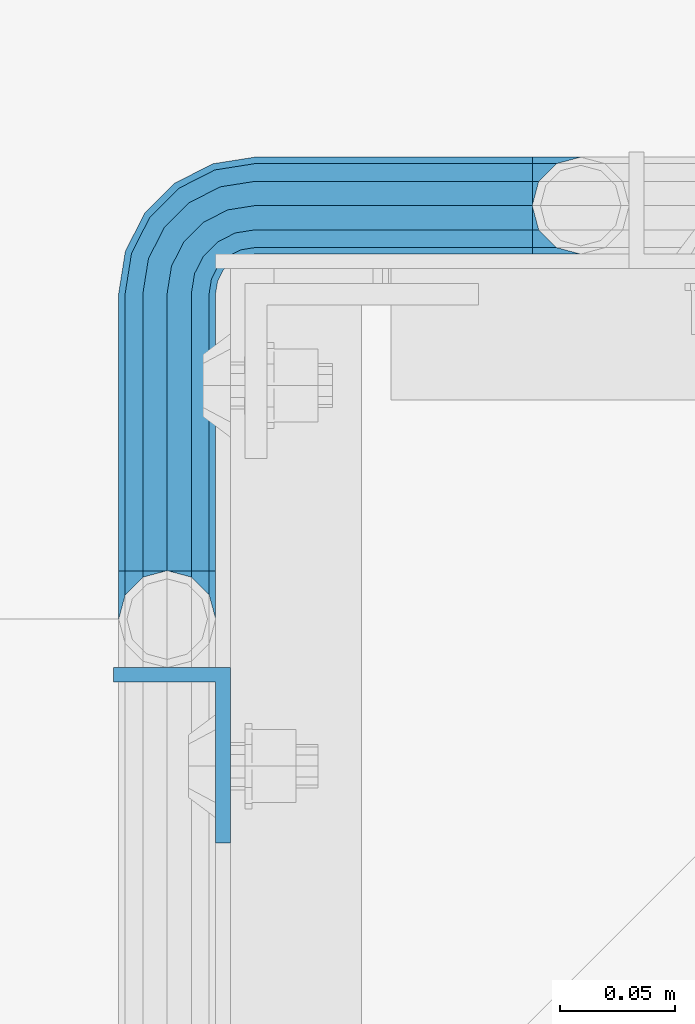
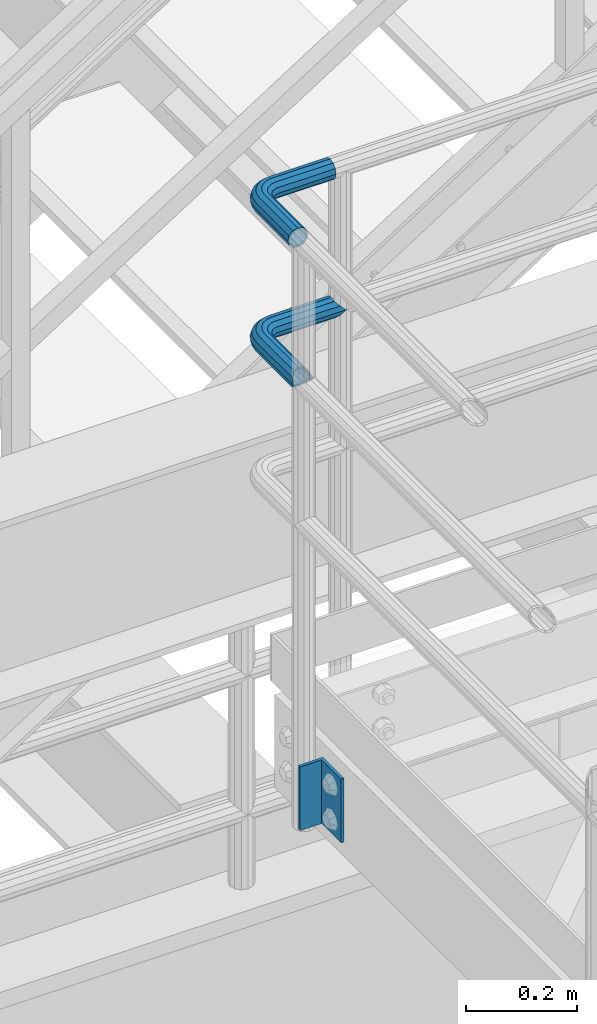
# One storey, part 1130 of 1876: 3 beams, 2 elements without a shape of their own.
"""IFC2X3 building model written with IfcOpenShell, lengths in millimetres."""

from ifc_helpers import new_model, si_unit, frame, origin_with_axes, place, context, subcontext, project, spatial, faceted_brep, material, type_object, element, aggregate, save


model = new_model("IFC2X3")

# Units and contexts
model_context = context("Model", 3, precision=1e-05, world=origin_with_axes())
body_context = subcontext(model_context, "Body", "Model", "MODEL_VIEW")
ifc_project = project(units=[si_unit("LENGTHUNIT", "METRE", prefix="MILLI"), si_unit("AREAUNIT", "SQUARE_METRE"), si_unit("VOLUMEUNIT", "CUBIC_METRE"), si_unit("MASSUNIT", "GRAM", prefix="KILO"), si_unit("TIMEUNIT", "SECOND"), si_unit("PLANEANGLEUNIT", "RADIAN"), si_unit("SOLIDANGLEUNIT", "STERADIAN"), si_unit("THERMODYNAMICTEMPERATUREUNIT", "DEGREE_CELSIUS"), si_unit("LUMINOUSINTENSITYUNIT", "LUMEN")], contexts=[model_context])

# Site, building, storey
site_placement = place(None, origin_with_axes())
site = spatial("IfcSite", under=ifc_project, at=site_placement, CompositionType="ELEMENT")
building_placement = place(site_placement, origin_with_axes())
building = spatial("IfcBuilding", under=site, at=building_placement, Name="Undefined", CompositionType="ELEMENT")
storey_placement = place(building_placement, origin_with_axes())
storey = spatial("IfcBuildingStorey", under=building, at=storey_placement, Name="Undefined", CompositionType="ELEMENT", Elevation=0.0)

# Assembly, beams
assembly_1_placement = place(storey_placement, origin_with_axes())
assembly_1 = element("IfcElementAssembly", 1, at=assembly_1_placement, inside=storey, Name="HANDRAIL", AssemblyPlace="NOTDEFINED", PredefinedType="RIGID_FRAME")
ifc_material_1 = material()
beam_type_1 = type_object("IfcBeamType", Name="PIPE1-1/4STD", PredefinedType="NOTDEFINED")
beam_1_placement = place(assembly_1_placement, frame((3517.90474593762, -7694.13240429563, 8785.225), z_axis=(0.0, 0.0, -1.0), x_axis=(-1.0, 0.0, 0.0)))
beam_1 = element("IfcBeam", 2, at=beam_1_placement, type_object=beam_type_1, material=ifc_material_1, Name="HANDRAIL", ObjectType="PIPE1-1/4STD", context=body_context, shape_type="Brep", body=[
    faceted_brep([(9.09494701772928e-13, 21.0820000000003, 0.0), (10.5409999957128, 18.2575475579433, -10.5409999999993), (10.5409999999983, 18.2575475625836, 10.5410000000011), (10.5409999999983, -18.2575475625836, 10.5410000000011), (10.5409999957128, -18.2575475672238, -10.5409999999993), (9.09494701772928e-13, -21.0820000000003, 0.0), (18.2575475625817, -10.5410000000011, 18.2575475625836), (18.2575475625817, -10.5409999999974, 13.3999612267289), (13.6205863358537, -15.1779612267255, 8.76300000000083), (11.2725475625793, -17.5259999999998, 0.0), (13.6205863358537, -15.1779612267255, -8.76299999999901), (18.2575475625817, -10.5409999999974, -13.3999612267271), (18.2575475625817, -10.5410000000011, -18.2575475625836), (21.0819999999985, 0.0, -17.5259999999998), (21.0819999999985, 0.0, -21.0819999999985), (18.7339612267233, -8.76300000000083, -15.1779612267255), (18.7339612267251, 8.76299999999901, -15.1779612267255), (18.2575475625817, 10.5410000000011, -13.3999612267235), (18.2575475625817, 10.5409999999993, -18.2575475625836), (13.6205863358573, 15.1779612267255, -8.76299999999901), (11.2725475625839, 17.5259999999998, 0.0), (13.6205863358573, 15.1779612267255, 8.76300000000083), (18.2575475625817, 10.5410000000011, 13.3999612267253), (18.2575475625817, 10.5409999999993, 18.2575475625836), (18.7339612267251, 8.76299999999901, 15.1779612267273), (21.0819999999985, 1.81898940354586e-12, 17.5259999999998), (21.0819999999985, 1.81898940354586e-12, 21.0820000000003), (18.7339612267233, -8.76300000000083, 15.1779612267273), (141.7320022583, -8.7629999999981, 15.1779612267255), (141.7320022583, 1.81898940354586e-12, 17.525999999998), (153.505549272468, -1.86474665447258, 17.525999999998), (150.797633350759, -10.1988549067664, 15.1779612267237), (141.7320022583, -15.1779612267246, 8.76299999999901), (148.815301313444, -16.2998455832249, 8.76299999999901), (141.732002258301, -17.5259999999989, -1.81898940354586e-12), (148.08971742905, -18.5329631590612, -1.81898940354586e-12), (141.7320022583, -15.1779612267246, -8.76300000000083), (148.815301313443, -16.2998455832249, -8.76300000000083), (141.7320022583, -8.76299999999901, -15.1779612267273), (150.797633350759, -10.1988549067664, -15.1779612267273), (141.7320022583, 1.81898940354586e-12, -17.5260000000017), (153.505549272467, -1.86474665447258, -17.5260000000017), (141.7320022583, 8.76300000000174, -15.1779612267273), (156.213465194176, 6.46936159782217, -15.1779612267273), (141.7320022583, 15.1779612267273, -8.76300000000083), (158.195797231491, 12.5703522742806, -8.76300000000083), (141.7320022583, 17.5260000000017, -1.81898940354586e-12), (158.921381115884, 14.803469850116, -1.81898940354586e-12), (141.7320022583, 15.1779612267273, 8.76299999999901), (158.195797231491, 12.5703522742806, 8.76299999999901), (141.7320022583, 8.76300000000174, 15.1779612267255), (156.213465194176, 6.46936159782217, 15.1779612267237), (179.832000732422, -38.0999984741202, -17.5260000000017), (171.069000732422, -38.0999984741202, -15.1779612267273), (171.069000732422, -161.097989750122, -15.1779612267255), (179.832000732422, -158.7499511731, -17.5259999999998), (188.595000732423, -38.0999984741202, -15.1779612267273), (188.595000732422, -161.097990142627, -15.1779612267255), (169.291000732422, -38.0999984741202, -18.2575475625854), (179.832000732422, -38.0999984741202, -21.0820000000003), (179.832000732422, -158.7499511731, -21.0820000000003), (169.291000732422, -161.574403610517, -18.2575475625836), (161.574453169838, -38.0999984741193, -10.5410000000011), (161.574453169838, -169.2909511731, -10.5409999999993), (158.750000732422, -38.0999984741193, -1.81898940354586e-12), (158.750000732422, -179.831954956055, 0.0), (161.574453169838, -169.2909511731, 10.5409999999993), (161.574453169839, -38.0999984741193, 10.5409999999993), (169.291000732423, -38.0999984741193, 18.2575475625817), (169.291000732422, -161.574403610517, 18.2575475625836), (179.832000732423, -38.0999984741193, 21.0819999999985), (179.832000732422, -158.7499511731, 21.0820000000003), (141.7320022583, 10.5410000000011, 18.2575475625817), (141.7320022583, 18.2575475625854, 10.5409999999993), (141.7320022583, 21.0820000000012, -1.81898940354586e-12), (141.7320022583, 18.2575475625854, -10.5410000000011), (141.7320022583, 10.5410000000011, -18.2575475625854), (141.7320022583, 1.81898940354586e-12, -21.0820000000022), (141.7320022583, -10.5409999999983, -18.2575475625854), (141.7320022583, -18.2575475625817, -10.5410000000011), (141.732002258301, -21.0819999999985, -1.81898940354586e-12), (141.7320022583, -18.2575475625817, 10.5409999999993), (141.7320022583, -10.5409999999983, 18.2575475625817), (141.7320022583, 1.81898940354586e-12, 21.0819999999985), (153.505549272468, -1.86474665447258, 21.0819999999985), (156.762897410175, 8.16034008379484, 18.2575475625817), (159.147441744916, 15.4992129264911, 10.5409999999993), (160.020245547882, 18.1854268220623, -1.81898940354586e-12), (159.147441744916, 15.4992129264911, -10.5410000000011), (156.762897410174, 8.16034008379484, -18.2575475625854), (153.505549272467, -1.86474665447258, -21.0820000000022), (150.24820113476, -11.8898333927391, -18.2575475625854), (147.863656800018, -19.2287062354353, -10.5410000000011), (146.990852997053, -21.9149201310065, -1.81898940354586e-12), (147.863656800019, -19.2287062354362, 10.5409999999993), (150.248201134761, -11.8898333927391, 18.2575475625817), (157.930775129339, -15.8043003606008, 18.2575475625817), (164.126619473753, -7.27645222289357, 21.0819999999985), (153.395102273439, -22.0471184766338, 10.5409999999993), (151.734930784924, -24.332148498308, -1.81898940354586e-12), (153.395102273439, -22.0471184766338, -10.5410000000011), (157.930775129338, -15.8043003606008, -18.2575475625854), (164.126619473752, -7.27645222289357, -21.0820000000022), (170.322463818167, 1.25139591481275, -18.2575475625854), (174.858136674066, 7.49421403084671, -10.5410000000011), (176.518308162581, 9.77924405251997, -1.81898940354586e-12), (174.858136674067, 7.49421403084671, 10.5409999999993), (170.322463818167, 1.25139591481275, 18.2575475625817), (172.555548509522, -15.7053812586619, 21.0819999999985), (181.083396647228, -9.50953691424547, 18.2575475625817), (164.027700371817, -21.9012256030774, 18.2575475625817), (157.784882255784, -26.4368984589782, 10.5409999999993), (155.499852234111, -28.0970699474938, -1.81898940354586e-12), (157.784882255784, -26.4368984589782, -10.5410000000011), (164.027700371817, -21.9012256030774, -18.2575475625854), (172.555548509522, -15.7053812586619, -21.0820000000022), (181.083396647228, -9.50953691424547, -18.2575475625854), (187.32621476326, -4.97386405834459, -10.5410000000011), (189.611244784934, -3.31369256982998, -1.81898940354586e-12), (187.32621476326, -4.97386405834459, 10.5409999999993), (187.992340816218, -23.0691033222502, 18.2575475625817), (195.331213658914, -20.6845589875093, 10.5409999999993), (177.96725407795, -26.3264514599559, 21.0819999999985), (167.942167339683, -29.5837995976626, 18.2575475625817), (160.603294496986, -31.9683439324035, 10.5409999999993), (157.917080601415, -32.8411477353693, -1.81898940354586e-12), (160.603294496986, -31.9683439324035, -10.5410000000011), (167.942167339682, -29.5837995976635, -18.2575475625854), (177.96725407795, -26.3264514599568, -21.0820000000022), (187.992340816217, -23.0691033222511, -18.2575475625854), (195.331213658914, -20.6845589875093, -10.5410000000011), (198.017427554485, -19.8117551845444, -1.81898940354586e-12), (198.089548295007, -38.0999984741193, 10.5409999999993), (200.914000732423, -38.0999984741202, -1.81898940354586e-12), (190.373000732423, -38.0999984741193, 18.2575475625817), (190.373000732422, -38.0999984741202, -18.2575475625854), (198.089548295006, -38.0999984741202, -10.5410000000011), (200.913999999997, -179.831951173101, 0.0), (198.089548295005, -169.2909511731, -10.5409999999993), (190.373000732422, -161.574403610517, -18.2575475625836), (190.372999999998, -161.574403610517, -13.3999619591505), (169.290999999997, -161.574403610517, -13.3999604943019), (164.654039505696, -38.0999984741193, -8.76300000000083), (164.654039505696, -166.211364104819, -8.76300000000083), (162.306000732422, -38.0999984741193, -1.81898940354586e-12), (162.306000732422, -168.559402878092, 0.0), (164.654039505696, -166.211364104819, 8.76299999999901), (169.290999999997, -161.574403610517, 13.3999604943019), (164.654039505696, -38.0999984741193, 8.76299999999901), (171.069000732422, -38.0999984741193, 15.1779612267255), (171.069000732422, -161.097989750122, 15.1779612267255), (179.832000732422, -158.7499511731, 17.5259999999998), (179.832000732423, -38.0999984741193, 17.525999999998), (188.595000732423, -38.0999984741193, 15.1779612267255), (188.595000732422, -161.097990142627, 15.1779612267255), (197.358000732423, -38.0999984741202, -1.81898940354586e-12), (195.009961959149, -38.0999984741202, -8.76300000000083), (195.009961959148, -166.211365569668, -8.76300000000083), (197.358000732422, -168.559404342942, 0.0), (195.009961959149, -38.0999984741193, 8.76299999999901), (195.009961959148, -166.211365569668, 8.76299999999901), (190.372999999998, -161.574403610517, 13.3999619591505), (190.373000732422, -161.574403610517, 18.2575475625836), (198.089548295005, -169.2909511731, 10.5409999999993), (186.301362330245, -23.6185355382495, -15.1779612267273), (192.402353006703, -21.6362035009342, -8.76300000000083), (177.96725407795, -26.3264514599568, -17.5260000000017), (169.633145825655, -29.0343673816642, -15.1779612267273), (163.532155149196, -31.0166994189794, -8.76300000000083), (161.299037573361, -31.7422833033716, -1.81898940354586e-12), (163.532155149197, -31.0166994189785, 8.76299999999901), (169.633145825655, -29.0343673816642, 15.1779612267255), (177.96725407795, -26.3264514599568, 17.525999999998), (186.301362330245, -23.6185355382486, 15.1779612267255), (192.402353006703, -21.6362035009342, 8.76299999999901), (194.635470582539, -20.9106196165412, -1.81898940354586e-12), (184.834777081907, -6.78399948972401, -8.76300000000083), (186.734380352937, -5.40385692698237, -1.81898940354586e-12), (179.644964431229, -10.5546190928217, -15.1779612267273), (172.555548509522, -15.7053812586619, -17.5260000000017), (165.466132587815, -20.8561434245012, -15.1779612267273), (160.276319937137, -24.6267630275997, -8.76300000000083), (158.376716666108, -26.0069055903414, -1.81898940354586e-12), (160.276319937138, -24.6267630275997, 8.76299999999901), (165.466132587815, -20.8561434245012, 15.1779612267237), (172.555548509522, -15.7053812586619, 17.525999999998), (179.64496443123, -10.5546190928217, 15.1779612267237), (184.834777081907, -6.7839994897231, 8.76299999999901), (174.428143805429, 6.90237962052288, -1.81898940354586e-12), (173.048001242688, 5.00277634949271, 8.76299999999901), (173.048001242688, 5.00277634949271, -8.76300000000083), (169.277381639591, -0.187036301185799, -15.1779612267273), (164.126619473753, -7.27645222289357, -17.5260000000017), (158.975857307914, -14.3658681446022, -15.1779612267273), (155.205237704817, -19.5556807952798, -8.76300000000083), (153.825095142076, -21.45528406631, -1.81898940354586e-12), (155.205237704817, -19.5556807952798, 8.76299999999901), (158.975857307914, -14.3658681446022, 15.1779612267237), (164.126619473753, -7.27645222289357, 17.525999999998), (169.277381639591, -0.187036301185799, 15.1779612267237)], [[[0, 1, 2]], [[3, 4, 5]], [[6, 7, 8, 9, 10, 11, 12, 4, 3]], [[13, 14, 12, 11, 15]], [[16, 17, 18, 14, 13]], [[2, 1, 18, 17, 19, 20, 21, 22, 23]], [[23, 22, 24, 25, 26]], [[26, 25, 27, 7, 6]], [[28, 29, 30, 31]], [[32, 28, 31, 33]], [[34, 32, 33, 35]], [[36, 34, 35, 37]], [[38, 36, 37, 39]], [[40, 38, 39, 41]], [[42, 40, 41, 43]], [[44, 42, 43, 45]], [[46, 44, 45, 47]], [[48, 46, 47, 49]], [[50, 48, 49, 51]], [[52, 53, 54, 55]], [[56, 52, 55, 57]], [[58, 59, 60, 61]], [[62, 58, 61, 63]], [[64, 62, 63, 65]], [[65, 63, 66]], [[67, 64, 65, 66]], [[68, 67, 66, 69]], [[70, 68, 69, 71]], [[72, 73, 2, 23]], [[73, 74, 0, 2]], [[74, 75, 1, 0]], [[75, 76, 18, 1]], [[76, 77, 14, 18]], [[77, 78, 12, 14]], [[78, 79, 4, 12]], [[79, 80, 5, 4]], [[80, 81, 3, 5]], [[81, 82, 6, 3]], [[82, 83, 26, 6]], [[83, 72, 23, 26]], [[72, 83, 84, 85]], [[73, 72, 85, 86]], [[74, 73, 86, 87]], [[75, 74, 87, 88]], [[76, 75, 88, 89]], [[77, 76, 89, 90]], [[78, 77, 90, 91]], [[79, 78, 91, 92]], [[80, 79, 92, 93]], [[81, 80, 93, 94]], [[82, 81, 94, 95]], [[83, 82, 95, 84]], [[95, 96, 97, 84]], [[94, 98, 96, 95]], [[93, 99, 98, 94]], [[92, 100, 99, 93]], [[91, 101, 100, 92]], [[90, 102, 101, 91]], [[89, 103, 102, 90]], [[88, 104, 103, 89]], [[87, 105, 104, 88]], [[86, 106, 105, 87]], [[85, 107, 106, 86]], [[84, 97, 107, 85]], [[97, 108, 109, 107]], [[96, 110, 108, 97]], [[98, 111, 110, 96]], [[99, 112, 111, 98]], [[100, 113, 112, 99]], [[101, 114, 113, 100]], [[102, 115, 114, 101]], [[103, 116, 115, 102]], [[104, 117, 116, 103]], [[105, 118, 117, 104]], [[106, 119, 118, 105]], [[107, 109, 119, 106]], [[109, 120, 121, 119]], [[108, 122, 120, 109]], [[110, 123, 122, 108]], [[111, 124, 123, 110]], [[112, 125, 124, 111]], [[113, 126, 125, 112]], [[114, 127, 126, 113]], [[115, 128, 127, 114]], [[116, 129, 128, 115]], [[117, 130, 129, 116]], [[118, 131, 130, 117]], [[119, 121, 131, 118]], [[121, 132, 133, 131]], [[120, 134, 132, 121]], [[122, 70, 134, 120]], [[123, 68, 70, 122]], [[124, 67, 68, 123]], [[125, 64, 67, 124]], [[126, 62, 64, 125]], [[127, 58, 62, 126]], [[128, 59, 58, 127]], [[129, 135, 59, 128]], [[130, 136, 135, 129]], [[131, 133, 136, 130]], [[136, 133, 137, 138]], [[135, 136, 138, 139]], [[59, 135, 139, 60]], [[57, 55, 60, 139, 140]], [[54, 141, 61, 60, 55]], [[53, 142, 143, 141, 54]], [[142, 144, 145, 143]], [[66, 63, 61, 141, 143, 145, 146, 147, 69]], [[144, 148, 146, 145]], [[146, 148, 149, 150, 147]], [[69, 147, 150, 151, 71]], [[149, 152, 151, 150]], [[152, 153, 154, 151]], [[155, 156, 157, 158]], [[159, 155, 158, 160]], [[154, 153, 159, 160, 161]], [[71, 151, 154, 161, 162]], [[134, 70, 71, 162]], [[132, 134, 162, 163]], [[133, 132, 163, 137]], [[137, 163, 138]], [[162, 161, 160, 158, 157, 140, 139, 138, 163]], [[156, 56, 57, 140, 157]], [[164, 56, 156, 165]], [[166, 52, 56, 164]], [[167, 53, 52, 166]], [[168, 142, 53, 167]], [[169, 144, 142, 168]], [[170, 148, 144, 169]], [[171, 149, 148, 170]], [[172, 152, 149, 171]], [[173, 153, 152, 172]], [[174, 159, 153, 173]], [[175, 155, 159, 174]], [[165, 156, 155, 175]], [[176, 165, 175, 177]], [[178, 164, 165, 176]], [[179, 166, 164, 178]], [[180, 167, 166, 179]], [[181, 168, 167, 180]], [[182, 169, 168, 181]], [[183, 170, 169, 182]], [[184, 171, 170, 183]], [[185, 172, 171, 184]], [[186, 173, 172, 185]], [[187, 174, 173, 186]], [[177, 175, 174, 187]], [[188, 177, 187, 189]], [[190, 176, 177, 188]], [[191, 178, 176, 190]], [[192, 179, 178, 191]], [[193, 180, 179, 192]], [[194, 181, 180, 193]], [[195, 182, 181, 194]], [[196, 183, 182, 195]], [[197, 184, 183, 196]], [[198, 185, 184, 197]], [[199, 186, 185, 198]], [[189, 187, 186, 199]], [[49, 189, 199, 51]], [[47, 188, 189, 49]], [[45, 190, 188, 47]], [[43, 191, 190, 45]], [[41, 192, 191, 43]], [[39, 193, 192, 41]], [[37, 194, 193, 39]], [[35, 195, 194, 37]], [[33, 196, 195, 35]], [[31, 197, 196, 33]], [[30, 198, 197, 31]], [[51, 199, 198, 30]], [[29, 50, 51, 30]], [[50, 29, 25, 24]], [[21, 48, 50, 24, 22]], [[46, 48, 21, 20]], [[44, 46, 20, 19]], [[42, 44, 19, 17, 16]], [[40, 42, 16, 13]], [[38, 40, 13, 15]], [[10, 36, 38, 15, 11]], [[34, 36, 10, 9]], [[32, 34, 9, 8]], [[28, 32, 8, 7, 27]], [[29, 28, 27, 25]]]),
])
beam_2_placement = place(assembly_1_placement, frame((3496.87037093762, -7694.13240429563, 9090.025), z_axis=(0.0, 0.0, -1.0), x_axis=(-1.0, 0.0, 0.0)))
beam_2 = element("IfcBeam", 3, at=beam_2_placement, type_object=beam_type_1, material=ifc_material_1, Name="HANDRAIL", ObjectType="PIPE1-1/4STD", context=body_context, shape_type="Brep", body=[
    faceted_brep([(9.09494701772928e-13, -21.0820000000003, 0.0), (0.0, -18.2575475625836, -10.5409999999993), (120.697624206543, -18.2575475625817, -10.5410000000011), (120.697624206543, -21.0819999999985, -1.81898940354586e-12), (0.0, -10.5410000000002, -18.2575475625836), (120.697624206543, -10.5409999999983, -18.2575475625854), (-4.28826751885936e-09, 0.0, -21.0820000000003), (120.697624206542, 1.81898940354586e-12, -21.0820000000022), (0.0, 10.5410000000002, -18.2575475625836), (120.697624206542, 10.5410000000011, -18.2575475625854), (0.0, 18.2575475625836, -10.5409999999993), (120.697624206542, 18.2575475625845, -10.5410000000011), (9.09494701772928e-13, 21.0820000000003, 0.0), (120.697624206542, 21.0820000000012, -1.81898940354586e-12), (0.0, 18.2575475625836, 10.5409999999993), (120.697624206543, 18.2575475625845, 10.5409999999993), (0.0, 10.5410000000002, 18.2575475625836), (120.697624206543, 10.5410000000011, 18.2575475625817), (0.0, 0.0, 21.0820000000003), (120.697624206543, 1.81898940354586e-12, 21.0819999999985), (0.0, -10.5410000000002, 18.2575475625836), (120.697624206543, -10.5409999999983, 18.2575475625817), (0.0, -18.2575475625836, 10.5409999999993), (120.697624206543, -18.2575475625817, 10.5409999999993), (0.0, -17.5259999999998, 0.0), (0.0, -15.1779612267264, 8.76300000000083), (120.697624206543, -15.1779612267246, 8.76299999999901), (120.697624206543, -17.5259999999989, -1.81898940354586e-12), (0.0, -8.76299999999992, 15.1779612267255), (120.697624206543, -8.76299999999901, 15.1779612267255), (0.0, 0.0, 17.5259999999998), (120.697624206543, 1.81898940354586e-12, 17.525999999998), (0.0, 8.76299999999992, 15.1779612267255), (120.697624206543, 8.76300000000174, 15.1779612267255), (0.0, 15.1779612267264, 8.76300000000083), (120.697624206543, 15.1779612267273, 8.76299999999901), (0.0, 17.5259999999998, 0.0), (120.697624206542, 17.5260000000017, -1.81898940354586e-12), (0.0, 15.1779612267264, -8.76300000000083), (120.697624206542, 15.1779612267273, -8.76300000000083), (0.0, 8.76299999999992, -15.1779612267255), (120.697624206542, 8.76300000000174, -15.1779612267273), (0.0, 0.0, -17.5259999999998), (120.697624206542, 1.81898940354586e-12, -17.5260000000017), (0.0, -8.76299999999992, -15.1779612267255), (120.697624206543, -8.76299999999901, -15.1779612267273), (0.0, -15.1779612267264, -8.76300000000083), (120.697624206543, -15.1779612267246, -8.76300000000083), (125.956474945295, -21.9149201310065, -1.81898940354586e-12), (126.829278748261, -19.2287062354353, 10.5409999999993), (129.213823083002, -11.8898333927391, 18.2575475625817), (132.471171220709, -1.86474665447258, 21.0819999999985), (135.728519358417, 8.16034008379484, 18.2575475625817), (138.113063693158, 15.4992129264911, 10.5409999999993), (138.985867496124, 18.1854268220613, -1.81898940354586e-12), (138.113063693158, 15.4992129264911, -10.5410000000011), (135.728519358416, 8.16034008379393, -18.2575475625854), (132.471171220709, -1.86474665447258, -21.0820000000022), (129.213823083002, -11.8898333927391, -18.2575475625854), (126.829278748261, -19.2287062354353, -10.5410000000011), (137.887003064126, 14.803469850116, -1.81898940354586e-12), (137.161419179733, 12.5703522742797, 8.76299999999901), (135.179087142418, 6.46936159782126, 15.1779612267237), (132.471171220709, -1.86474665447258, 17.525999999998), (129.763255299001, -10.1988549067664, 15.1779612267255), (127.780923261686, -16.2998455832249, 8.76299999999901), (127.055339377293, -18.5329631590612, -1.81898940354586e-12), (127.780923261686, -16.2998455832249, -8.76300000000083), (129.763255299001, -10.1988549067664, -15.1779612267273), (132.471171220709, -1.86474665447258, -17.5260000000017), (135.179087142417, 6.46936159782126, -15.1779612267273), (137.161419179733, 12.5703522742797, -8.76300000000083), (149.288085766415, 1.2513959148082, 18.2575475625817), (153.823758622315, 7.49421403084034, 10.5409999999993), (143.092241421999, -7.27645222289721, 21.0819999999985), (136.896397077584, -15.8043003606035, 18.2575475625817), (132.360724221684, -22.0471184766357, 10.5409999999993), (130.700552733168, -24.3321484983098, -1.81898940354586e-12), (132.360724221683, -22.0471184766357, -10.5410000000011), (136.896397077584, -15.8043003606035, -18.2575475625854), (143.092241421999, -7.27645222289811, -21.0820000000022), (149.288085766414, 1.2513959148082, -18.2575475625854), (153.823758622315, 7.49421403084034, -10.5410000000011), (155.48393011083, 9.77924405251451, -1.81898940354586e-12), (152.013623190936, 5.00277634948725, -8.76300000000083), (153.393765753678, 6.90237962051742, -1.81898940354586e-12), (148.243003587838, -0.187036301190346, -15.1779612267273), (143.092241421999, -7.27645222289721, -17.5260000000017), (137.94147925616, -14.365868144605, -15.1779612267273), (134.170859653062, -19.5556807952826, -8.76300000000083), (132.79071709032, -21.4552840663118, -1.81898940354586e-12), (134.170859653062, -19.5556807952826, 8.76299999999901), (137.94147925616, -14.365868144605, 15.1779612267255), (143.092241421999, -7.27645222289721, 17.525999999998), (148.243003587839, -0.187036301190346, 15.1779612267237), (152.013623190936, 5.00277634948725, 8.76299999999901), (160.04901859547, -9.50953691424547, 18.2575475625817), (166.291836711502, -4.9738640583455, 10.5409999999993), (151.521170457764, -15.7053812586619, 21.0819999999985), (142.993322320059, -21.9012256030783, 18.2575475625817), (136.750504204027, -26.4368984589792, 10.5409999999993), (134.465474182353, -28.0970699474938, -1.81898940354586e-12), (136.750504204027, -26.4368984589792, -10.5410000000011), (142.993322320058, -21.9012256030783, -18.2575475625854), (151.521170457764, -15.7053812586619, -21.0820000000022), (160.04901859547, -9.50953691424638, -18.2575475625854), (166.291836711502, -4.9738640583455, -10.5410000000011), (168.576866733175, -3.31369256982998, -1.81898940354586e-12), (163.800399030148, -6.78399948972401, -8.76300000000083), (165.700002301178, -5.40385692698237, -1.81898940354586e-12), (158.610586379471, -10.5546190928226, -15.1779612267273), (151.521170457764, -15.7053812586619, -17.5260000000017), (144.431754536057, -20.8561434245021, -15.1779612267273), (139.24194188538, -24.6267630275997, -8.76300000000083), (137.34233861435, -26.0069055903414, -1.81898940354586e-12), (139.24194188538, -24.6267630275997, 8.76299999999901), (144.431754536057, -20.8561434245021, 15.1779612267255), (151.521170457764, -15.7053812586619, 17.525999999998), (158.610586379471, -10.5546190928217, 15.1779612267255), (163.800399030148, -6.78399948972401, 8.76299999999901), (166.957962764459, -23.0691033222502, 18.2575475625817), (174.296835607155, -20.6845589875093, 10.5409999999993), (156.932876026191, -26.3264514599568, 21.0819999999985), (146.907789287925, -29.5837995976626, 18.2575475625817), (139.568916445228, -31.9683439324035, 10.5409999999993), (136.882702549657, -32.8411477353693, -1.81898940354586e-12), (139.568916445228, -31.9683439324044, -10.5410000000011), (146.907789287924, -29.5837995976635, -18.2575475625854), (156.932876026191, -26.3264514599568, -21.0820000000022), (166.957962764458, -23.0691033222502, -18.2575475625854), (174.296835607155, -20.6845589875093, -10.5410000000011), (176.983049502726, -19.8117551845444, -1.81898940354586e-12), (171.367974954944, -21.6362035009342, -8.76300000000083), (173.60109253078, -20.9106196165412, -1.81898940354586e-12), (165.266984278486, -23.6185355382495, -15.1779612267273), (156.932876026191, -26.3264514599568, -17.5260000000017), (148.598767773897, -29.0343673816642, -15.1779612267273), (142.497777097438, -31.0166994189794, -8.76300000000083), (140.264659521603, -31.7422833033725, -1.81898940354586e-12), (142.497777097438, -31.0166994189794, 8.76299999999901), (148.598767773897, -29.0343673816642, 15.1779612267255), (156.932876026191, -26.3264514599568, 17.525999999998), (165.266984278486, -23.6185355382486, 15.1779612267255), (171.367974954945, -21.6362035009342, 8.76299999999901), (148.256622680664, -38.0999984741202, -18.2575475625854), (140.54007511808, -38.0999984741202, -10.5410000000011), (158.797622680664, -38.0999984741202, -21.0820000000003), (169.338622680664, -38.0999984741202, -18.2575475625854), (177.055170243248, -38.0999984741202, -10.5410000000011), (179.879622680664, -38.0999984741193, -1.81898940354586e-12), (177.055170243248, -38.0999984741193, 10.5409999999993), (169.338622680664, -38.0999984741193, 18.2575475625817), (158.797622680665, -38.0999984741193, 21.0819999999985), (148.256622680664, -38.0999984741193, 18.2575475625817), (140.540075118081, -38.0999984741193, 10.5409999999993), (137.715622680664, -38.0999984741193, -1.81898940354586e-12), (173.975583907391, -38.0999984741202, -8.76300000000083), (176.323622680664, -38.0999984741193, -1.81898940354586e-12), (167.560622680664, -38.0999984741202, -15.1779612267273), (158.797622680664, -38.0999984741202, -17.5260000000017), (150.034622680664, -38.0999984741202, -15.1779612267273), (143.619661453938, -38.0999984741202, -8.76300000000083), (141.271622680664, -38.0999984741193, -1.81898940354586e-12), (143.619661453938, -38.0999984741193, 8.76299999999901), (150.034622680665, -38.0999984741193, 15.1779612267255), (158.797622680665, -38.0999984741193, 17.525999999998), (167.560622680664, -38.0999984741193, 15.1779612267255), (173.975583907391, -38.0999984741193, 8.76299999999901), (140.54007511808, -158.797576904297, -10.5409999999993), (137.715622680664, -158.797576904297, 0.0), (148.256622680664, -158.797576904297, -18.2575475625836), (158.797622680664, -158.797576904297, -21.0820000000003), (169.338622680664, -158.797576904297, -18.2575475625836), (177.055170243248, -158.797576904297, -10.5409999999993), (179.879622680664, -158.797576904297, 0.0), (177.055170243248, -158.797576904297, 10.5409999999993), (169.338622680664, -158.797576904297, 18.2575475625836), (158.797622680664, -158.797576904297, 21.0820000000003), (148.256622680664, -158.797576904297, 18.2575475625836), (140.54007511808, -158.797576904297, 10.5409999999993), (143.619661453938, -158.797576904297, 8.76300000000083), (141.271622680664, -158.797576904297, 0.0), (150.034622680664, -158.797576904297, 15.1779612267255), (158.797622680664, -158.797576904297, 17.5259999999998), (167.560622680664, -158.797576904297, 15.1779612267255), (173.97558390739, -158.797576904297, 8.76300000000083), (176.323622680664, -158.797576904297, 0.0), (173.97558390739, -158.797576904297, -8.76300000000083), (167.560622680664, -158.797576904297, -15.1779612267255), (158.797622680664, -158.797576904297, -17.5259999999998), (150.034622680664, -158.797576904297, -15.1779612267255), (143.619661453938, -158.797576904297, -8.76300000000083)], [[[0, 1, 2, 3]], [[1, 4, 5, 2]], [[4, 6, 7, 5]], [[6, 8, 9, 7]], [[8, 10, 11, 9]], [[10, 12, 13, 11]], [[12, 14, 15, 13]], [[14, 16, 17, 15]], [[16, 18, 19, 17]], [[18, 20, 21, 19]], [[20, 22, 23, 21]], [[22, 0, 3, 23]], [[24, 25, 26, 27]], [[25, 28, 29, 26]], [[28, 30, 31, 29]], [[30, 32, 33, 31]], [[32, 34, 35, 33]], [[34, 36, 37, 35]], [[36, 38, 39, 37]], [[38, 40, 41, 39]], [[40, 42, 43, 41]], [[42, 44, 45, 43]], [[44, 46, 47, 45]], [[46, 24, 27, 47]], [[22, 20, 18, 16, 14, 12, 10, 8, 6, 4, 1, 0], [46, 44, 42, 40, 38, 36, 34, 32, 30, 28, 25, 24]], [[23, 3, 48, 49]], [[21, 23, 49, 50]], [[19, 21, 50, 51]], [[17, 19, 51, 52]], [[15, 17, 52, 53]], [[13, 15, 53, 54]], [[11, 13, 54, 55]], [[9, 11, 55, 56]], [[7, 9, 56, 57]], [[5, 7, 57, 58]], [[2, 5, 58, 59]], [[3, 2, 59, 48]], [[35, 37, 60, 61]], [[33, 35, 61, 62]], [[31, 33, 62, 63]], [[29, 31, 63, 64]], [[26, 29, 64, 65]], [[27, 26, 65, 66]], [[47, 27, 66, 67]], [[45, 47, 67, 68]], [[43, 45, 68, 69]], [[41, 43, 69, 70]], [[39, 41, 70, 71]], [[37, 39, 71, 60]], [[52, 72, 73, 53]], [[51, 74, 72, 52]], [[50, 75, 74, 51]], [[49, 76, 75, 50]], [[48, 77, 76, 49]], [[59, 78, 77, 48]], [[58, 79, 78, 59]], [[57, 80, 79, 58]], [[56, 81, 80, 57]], [[55, 82, 81, 56]], [[54, 83, 82, 55]], [[53, 73, 83, 54]], [[71, 84, 85, 60]], [[70, 86, 84, 71]], [[69, 87, 86, 70]], [[68, 88, 87, 69]], [[67, 89, 88, 68]], [[66, 90, 89, 67]], [[65, 91, 90, 66]], [[64, 92, 91, 65]], [[63, 93, 92, 64]], [[62, 94, 93, 63]], [[61, 95, 94, 62]], [[60, 85, 95, 61]], [[72, 96, 97, 73]], [[74, 98, 96, 72]], [[75, 99, 98, 74]], [[76, 100, 99, 75]], [[77, 101, 100, 76]], [[78, 102, 101, 77]], [[79, 103, 102, 78]], [[80, 104, 103, 79]], [[81, 105, 104, 80]], [[82, 106, 105, 81]], [[83, 107, 106, 82]], [[73, 97, 107, 83]], [[84, 108, 109, 85]], [[86, 110, 108, 84]], [[87, 111, 110, 86]], [[88, 112, 111, 87]], [[89, 113, 112, 88]], [[90, 114, 113, 89]], [[91, 115, 114, 90]], [[92, 116, 115, 91]], [[93, 117, 116, 92]], [[94, 118, 117, 93]], [[95, 119, 118, 94]], [[85, 109, 119, 95]], [[96, 120, 121, 97]], [[98, 122, 120, 96]], [[99, 123, 122, 98]], [[100, 124, 123, 99]], [[101, 125, 124, 100]], [[102, 126, 125, 101]], [[103, 127, 126, 102]], [[104, 128, 127, 103]], [[105, 129, 128, 104]], [[106, 130, 129, 105]], [[107, 131, 130, 106]], [[97, 121, 131, 107]], [[108, 132, 133, 109]], [[110, 134, 132, 108]], [[111, 135, 134, 110]], [[112, 136, 135, 111]], [[113, 137, 136, 112]], [[114, 138, 137, 113]], [[115, 139, 138, 114]], [[116, 140, 139, 115]], [[117, 141, 140, 116]], [[118, 142, 141, 117]], [[119, 143, 142, 118]], [[109, 133, 143, 119]], [[127, 144, 145, 126]], [[128, 146, 144, 127]], [[129, 147, 146, 128]], [[130, 148, 147, 129]], [[131, 149, 148, 130]], [[121, 150, 149, 131]], [[120, 151, 150, 121]], [[122, 152, 151, 120]], [[123, 153, 152, 122]], [[124, 154, 153, 123]], [[125, 155, 154, 124]], [[126, 145, 155, 125]], [[132, 156, 157, 133]], [[134, 158, 156, 132]], [[135, 159, 158, 134]], [[136, 160, 159, 135]], [[137, 161, 160, 136]], [[138, 162, 161, 137]], [[139, 163, 162, 138]], [[140, 164, 163, 139]], [[141, 165, 164, 140]], [[142, 166, 165, 141]], [[143, 167, 166, 142]], [[133, 157, 167, 143]], [[155, 145, 168, 169]], [[145, 144, 170, 168]], [[144, 146, 171, 170]], [[146, 147, 172, 171]], [[147, 148, 173, 172]], [[148, 149, 174, 173]], [[149, 150, 175, 174]], [[150, 151, 176, 175]], [[151, 152, 177, 176]], [[152, 153, 178, 177]], [[153, 154, 179, 178]], [[154, 155, 169, 179]], [[162, 163, 180, 181]], [[163, 164, 182, 180]], [[164, 165, 183, 182]], [[165, 166, 184, 183]], [[166, 167, 185, 184]], [[167, 157, 186, 185]], [[157, 156, 187, 186]], [[156, 158, 188, 187]], [[158, 159, 189, 188]], [[159, 160, 190, 189]], [[160, 161, 191, 190]], [[161, 162, 181, 191]], [[170, 171, 172, 173, 174, 175, 176, 177, 178, 179, 169, 168], [182, 183, 184, 185, 186, 187, 188, 189, 190, 191, 181, 180]]]),
])
aggregate(assembly_1, [beam_1, beam_2])

# Assembly, beam
assembly_2_placement = place(storey_placement, origin_with_axes())
assembly_2 = element("IfcElementAssembly", 4, at=assembly_2_placement, inside=storey, Name="HANDRAIL", AssemblyPlace="NOTDEFINED", PredefinedType="RIGID_FRAME")
ifc_material_2 = material(Name="STEEL/A36")
beam_type_2 = type_object("IfcBeamType", Name="L3X2X1/4", PredefinedType="NOTDEFINED")
beam_3_placement = place(assembly_2_placement, frame((3340.10333884985, -7933.14635546873, 7966.075), z_axis=(0.0, -1.0, 0.0), x_axis=(0.0, 0.0, -1.0)))
beam_3 = element("IfcBeam", 5, at=beam_3_placement, type_object=beam_type_2, material=ifc_material_2, Name="ANGLE", ObjectType="L3X2X1/4", context=body_context, shape_type="Brep", body=[
    faceted_brep([(0.0, 25.3999999999996, -38.1000000000004), (0.0, 25.3999999999996, 38.1000000000004), (139.7, 25.3999999999996, 38.1000000000004), (139.7, 25.3999999999996, -38.1000000000004), (0.0, 19.0500000000002, 38.1000000000004), (139.7, 19.0500000000002, 38.1000000000004), (0.0, 19.0500000000002, -31.75), (139.7, 19.0500000000002, -31.75), (0.0, -25.3999999999996, -31.75), (139.7, -25.3999999999996, -31.75), (0.0, -25.3999999999996, -38.1000000000004), (139.7, -25.3999999999996, -38.1000000000004)], [[[0, 1, 2, 3]], [[1, 4, 5, 2]], [[4, 6, 7, 5]], [[6, 8, 9, 7]], [[8, 10, 11, 9]], [[10, 0, 3, 11]], [[5, 7, 9, 11, 3, 2]], [[10, 8, 6, 4, 1, 0]]]),
])
aggregate(assembly_2, [beam_3])

save(model, "model.ifc")
